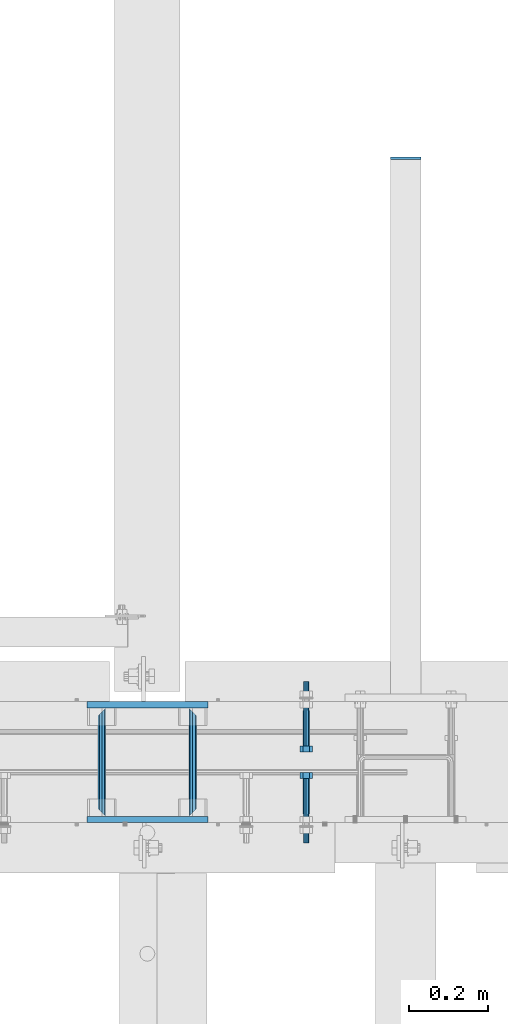
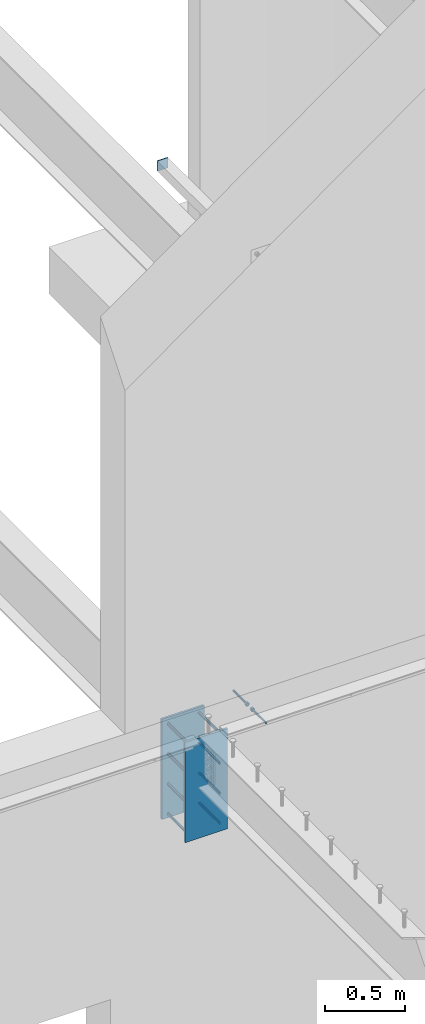
# One storey, part 435 of 975: 13 beams.
"""IFC2X3 building model written with IfcOpenShell, lengths in millimetres."""

from ifc_helpers import new_model, si_unit, frame, origin_with_axes, place, context, subcontext, project, spatial, faceted_brep, material, type_object, element, save


model = new_model("IFC2X3")

# Units and contexts
model_context = context("Model", 3, precision=1e-05, world=origin_with_axes())
body_context = subcontext(model_context, "Body", "Model", "MODEL_VIEW")
ifc_project = project(units=[si_unit("LENGTHUNIT", "METRE", prefix="MILLI"), si_unit("AREAUNIT", "SQUARE_METRE"), si_unit("VOLUMEUNIT", "CUBIC_METRE"), si_unit("MASSUNIT", "GRAM", prefix="KILO"), si_unit("TIMEUNIT", "SECOND"), si_unit("PLANEANGLEUNIT", "RADIAN"), si_unit("SOLIDANGLEUNIT", "STERADIAN"), si_unit("THERMODYNAMICTEMPERATUREUNIT", "DEGREE_CELSIUS"), si_unit("LUMINOUSINTENSITYUNIT", "LUMEN")], contexts=[model_context])

# Site, building, storey
site_placement = place(None, origin_with_axes())
site = spatial("IfcSite", under=ifc_project, at=site_placement, CompositionType="ELEMENT")
building_placement = place(site_placement, origin_with_axes())
building = spatial("IfcBuilding", under=site, at=building_placement, Name="Undefined", CompositionType="ELEMENT")
storey_placement = place(building_placement, origin_with_axes())
storey = spatial("IfcBuildingStorey", under=building, at=storey_placement, Name="Undefined", CompositionType="ELEMENT", Elevation=0.0)

# Beams
ifc_material_1 = material(Name="STEEL/F1554-36")
beam_type_1 = type_object("IfcBeamType", PredefinedType="NOTDEFINED")
beam_1_placement = place(storey_placement, frame((11258.5499755824, 20726.3999996637, 3886.2), z_axis=(0.0, 0.0, -1.0), x_axis=(0.0, -1.0, 0.0)))
element("IfcBeam", 1, at=beam_1_placement, inside=storey, type_object=beam_type_1, material=ifc_material_1, Name="HEADED_ANCHOR_BOLT", context=body_context, shape_type="Brep", body=[
    faceted_brep([(88.9000000184824, 7.94000001861696, -13.7499999799138), (88.8999999527368, 15.8800000758411, 2.00943759409711e-08), (104.774999952569, 15.8800001213949, 6.97191353538074e-08), (104.775000018315, 7.94000006417082, -13.7499999302891), (88.900000064019, -7.94000009583215, -13.7499999799147), (104.775000063852, -7.9400000502792, -13.74999993029), (88.9000000438027, -15.880000153059, 2.00925569515675e-08), (104.775000043643, -15.8800001075042, 6.9716406869702e-08), (88.8999999780608, -7.94000009583488, 13.7500000200998), (104.774999977893, -7.94000005028101, 13.7500000697237), (88.8999999325279, 7.94000001861514, 13.7500000201007), (104.774999932361, 7.940000064169, 13.7500000697246), (88.9000000119959, 3.78780480527439, -7.86545778426807), (88.8999999957159, 6.82538844544797, -5.4430656647246), (88.8999999799416, 8.51112018845743, -1.94260763148395), (88.8999999677944, 8.51112018845652, 1.94260767167179), (88.8999999616899, 6.82538844544615, 5.44306570491244), (88.8999999628249, 3.78780480527257, 7.86545782445592), (88.8999999709849, -3.86089595849626e-08, 8.72999956233434), (88.8999999845473, -3.7878048824914, 7.8654578244541), (88.9000000008309, -6.82538852266407, 5.44306570491153), (88.9000000166052, -8.51112026567444, 1.94260767166998), (88.9000000287488, -8.51112026567353, -1.94260763148577), (88.9000000348606, -6.82538852266407, -5.44306566472642), (88.9000000337182, -3.78780488248958, -7.86545778426898), (88.9000000255583, -3.86080500902608e-08, -8.72999952214832), (104.775000025395, 6.94581103743985e-09, -8.72999947252447), (104.775000011829, 3.78780485082825, -7.86545773464422), (104.774999995549, 6.82538849100092, -5.44306561510075), (104.774999979774, 8.51112023401038, -1.9426075818601), (104.774999967627, 8.51112023401038, 1.94260772129564), (104.774999961523, 6.82538849100092, 5.44306575453629), (104.774999962658, 3.78780485082643, 7.86545787407977), (104.774999970818, 6.94399204803631e-09, 8.7299996119591), (104.77499998438, -3.78780483693754, 7.86545787407886), (104.775000000664, -6.82538847711112, 5.44306575453538), (104.775000016438, -8.51112022012057, 1.94260772129473), (104.775000028581, -8.51112022012057, -1.94260758186101), (104.775000034693, -6.82538847711021, -5.44306561510166), (104.775000033551, -3.78780483693663, -7.86545773464422), (-2.99107341561466e-07, -5.61266007567065, 5.61266007566792), (-4.22995071858168e-07, -7.93750000000728, 0.0), (104.774999998088, -7.93749999999, -4.45652403868735e-11), (104.774999998088, -5.61266007565791, 5.61266007562426), (-1.09139364212751e-11, 1.81898940354586e-12, 7.9375), (104.774999998095, 1.18234311230481e-11, 7.93749999995816), (2.99089151667431e-07, 5.61266007567428, 5.61266007566792), (104.774999998102, 5.61266007568065, 5.61266007562517), (4.22980519942939e-07, 7.93750000001091, 0.0), (104.77499999811, 7.93750000001364, -4.36557456851006e-11), (2.99089151667431e-07, 5.61266007567428, -5.61266007566792), (104.774999998102, 5.61266007568156, -5.61266007571339), (-1.09139364212751e-11, 1.81898940354586e-12, -7.9375), (104.774999998099, 1.2732925824821e-11, -7.93750000004547), (-73.0249999592124, 5.05157065939329, -5.0515715445581), (-73.0249999269472, -1.85405951924622e-07, -7.14400069976364), (-73.0249999328516, -5.0515710302052, -5.05157154455992), (-73.0249999734697, -7.14400018541073, -6.9975976657588e-07), (-73.0250000250016, -5.05157103020611, 5.05157014504039), (-73.0250000572705, -1.85406861419324e-07, 7.1439993002441), (-73.0250000513661, 5.05157065939238, 5.05157014503948), (-73.025000010748, 7.14399981459792, -6.99758857081179e-07), (0.00625003290042514, 5.05157085007795, -5.05157087849238), (0.00625006516929716, 5.27870724909008e-09, -7.1440000336961), (0.00625005926485755, -5.05157083952145, -5.05157087849329), (0.00625001864682417, -7.14399999472516, -3.36940502165817e-08), (0.00624996711121639, -5.05157083952145, 5.05157081110519), (0.00624993484598235, 5.2777977543883e-09, 7.14399996631164), (0.00624994074678398, 5.05157085007704, 5.05157081110701), (0.00624998136845534, 7.14400000528167, -3.36922312271781e-08), (-2.99107341561466e-07, -5.61266007567065, -5.61266007566792), (104.774999998092, -5.612660075657, -5.6126600757143)], [[[0, 1, 2, 3]], [[4, 0, 3, 5]], [[6, 4, 5, 7]], [[8, 6, 7, 9]], [[10, 8, 9, 11]], [[0, 4, 6, 8, 10, 1], [12, 13, 14, 15, 16, 17, 18, 19, 20, 21, 22, 23, 24, 25]], [[12, 25, 26, 27]], [[13, 12, 27, 28]], [[14, 13, 28, 29]], [[15, 14, 29, 30]], [[16, 15, 30, 31]], [[17, 16, 31, 32]], [[18, 17, 32, 33]], [[19, 18, 33, 34]], [[20, 19, 34, 35]], [[21, 20, 35, 36]], [[22, 21, 36, 37]], [[23, 22, 37, 38]], [[24, 23, 38, 39]], [[25, 24, 39, 26]], [[9, 7, 5, 3, 2, 11], [38, 37, 36, 35, 34, 33, 32, 31, 30, 29, 28, 27, 26, 39]], [[1, 10, 11, 2]], [[40, 41, 42, 43]], [[44, 40, 43, 45]], [[46, 44, 45, 47]], [[48, 46, 47, 49]], [[50, 48, 49, 51]], [[52, 50, 51, 53]], [[54, 55, 56, 57, 58, 59, 60, 61]], [[55, 54, 62, 63]], [[56, 55, 63, 64]], [[57, 56, 64, 65]], [[58, 57, 65, 66]], [[59, 58, 66, 67]], [[60, 59, 67, 68]], [[61, 60, 68, 69]], [[54, 61, 69, 62]], [[40, 44, 46, 48, 50, 52, 70, 41], [68, 67, 66, 65, 64, 63, 62, 69]], [[41, 70, 71, 42]], [[53, 51, 49, 47, 45, 43, 42, 71]], [[70, 52, 53, 71]]]),
])
beam_2_placement = place(storey_placement, frame((11258.5499755824, 20466.05, 3886.2), z_axis=(0.0, 0.0, 1.0), x_axis=(0.0, 1.0, 0.0)))
element("IfcBeam", 2, at=beam_2_placement, inside=storey, type_object=beam_type_1, material=ifc_material_1, Name="HEADED_ANCHOR_BOLT", context=body_context, shape_type="Brep", body=[
    faceted_brep([(88.9000000184824, 7.94000001861696, -13.7499999799138), (88.8999999527368, 15.8800000758411, 2.00943759409711e-08), (104.774999952569, 15.8800001213949, 6.97191353538074e-08), (104.775000018315, 7.94000006417082, -13.7499999302891), (88.900000064019, -7.94000009583215, -13.7499999799147), (104.775000063852, -7.9400000502792, -13.74999993029), (88.9000000438027, -15.880000153059, 2.00925569515675e-08), (104.775000043643, -15.8800001075042, 6.9716406869702e-08), (88.8999999780608, -7.94000009583488, 13.7500000200998), (104.774999977893, -7.94000005028101, 13.7500000697237), (88.8999999325279, 7.94000001861514, 13.7500000201007), (104.774999932361, 7.940000064169, 13.7500000697246), (88.9000000119959, 3.78780480527439, -7.86545778426807), (88.8999999957159, 6.82538844544797, -5.4430656647246), (88.8999999799416, 8.51112018845743, -1.94260763148395), (88.8999999677944, 8.51112018845652, 1.94260767167179), (88.8999999616899, 6.82538844544615, 5.44306570491244), (88.8999999628249, 3.78780480527257, 7.86545782445592), (88.8999999709849, -3.86089595849626e-08, 8.72999956233434), (88.8999999845473, -3.7878048824914, 7.8654578244541), (88.9000000008309, -6.82538852266407, 5.44306570491153), (88.9000000166052, -8.51112026567444, 1.94260767166998), (88.9000000287488, -8.51112026567353, -1.94260763148577), (88.9000000348606, -6.82538852266407, -5.44306566472642), (88.9000000337182, -3.78780488248958, -7.86545778426898), (88.9000000255583, -3.86080500902608e-08, -8.72999952214832), (104.775000025395, 6.94581103743985e-09, -8.72999947252447), (104.775000011829, 3.78780485082825, -7.86545773464422), (104.774999995549, 6.82538849100092, -5.44306561510075), (104.774999979774, 8.51112023401038, -1.9426075818601), (104.774999967627, 8.51112023401038, 1.94260772129564), (104.774999961523, 6.82538849100092, 5.44306575453629), (104.774999962658, 3.78780485082643, 7.86545787407977), (104.774999970818, 6.94399204803631e-09, 8.7299996119591), (104.77499998438, -3.78780483693754, 7.86545787407886), (104.775000000664, -6.82538847711112, 5.44306575453538), (104.775000016438, -8.51112022012057, 1.94260772129473), (104.775000028581, -8.51112022012057, -1.94260758186101), (104.775000034693, -6.82538847711021, -5.44306561510166), (104.775000033551, -3.78780483693663, -7.86545773464422), (-2.99107341561466e-07, -5.61266007567065, 5.61266007566792), (-4.22995071858168e-07, -7.93750000000728, 0.0), (104.774999998088, -7.93749999999, -4.45652403868735e-11), (104.774999998088, -5.61266007565791, 5.61266007562426), (-1.09139364212751e-11, 1.81898940354586e-12, 7.9375), (104.774999998095, 1.18234311230481e-11, 7.93749999995816), (2.99089151667431e-07, 5.61266007567428, 5.61266007566792), (104.774999998102, 5.61266007568065, 5.61266007562517), (4.22980519942939e-07, 7.93750000001091, 0.0), (104.77499999811, 7.93750000001364, -4.36557456851006e-11), (2.99089151667431e-07, 5.61266007567428, -5.61266007566792), (104.774999998102, 5.61266007568156, -5.61266007571339), (-1.09139364212751e-11, 1.81898940354586e-12, -7.9375), (104.774999998099, 1.2732925824821e-11, -7.93750000004547), (-73.0249999592124, 5.05157065939329, -5.0515715445581), (-73.0249999269472, -1.85405951924622e-07, -7.14400069976364), (-73.0249999328516, -5.0515710302052, -5.05157154455992), (-73.0249999734697, -7.14400018541073, -6.9975976657588e-07), (-73.0250000250016, -5.05157103020611, 5.05157014504039), (-73.0250000572705, -1.85406861419324e-07, 7.1439993002441), (-73.0250000513661, 5.05157065939238, 5.05157014503948), (-73.025000010748, 7.14399981459792, -6.99758857081179e-07), (0.00625003290042514, 5.05157085007795, -5.05157087849238), (0.00625006516929716, 5.27870724909008e-09, -7.1440000336961), (0.00625005926485755, -5.05157083952145, -5.05157087849329), (0.00625001864682417, -7.14399999472516, -3.36940502165817e-08), (0.00624996711121639, -5.05157083952145, 5.05157081110519), (0.00624993484598235, 5.2777977543883e-09, 7.14399996631164), (0.00624994074678398, 5.05157085007704, 5.05157081110701), (0.00624998136845534, 7.14400000528167, -3.36922312271781e-08), (-2.99107341561466e-07, -5.61266007567065, -5.61266007566792), (104.774999998092, -5.612660075657, -5.6126600757143)], [[[0, 1, 2, 3]], [[4, 0, 3, 5]], [[6, 4, 5, 7]], [[8, 6, 7, 9]], [[10, 8, 9, 11]], [[0, 4, 6, 8, 10, 1], [12, 13, 14, 15, 16, 17, 18, 19, 20, 21, 22, 23, 24, 25]], [[12, 25, 26, 27]], [[13, 12, 27, 28]], [[14, 13, 28, 29]], [[15, 14, 29, 30]], [[16, 15, 30, 31]], [[17, 16, 31, 32]], [[18, 17, 32, 33]], [[19, 18, 33, 34]], [[20, 19, 34, 35]], [[21, 20, 35, 36]], [[22, 21, 36, 37]], [[23, 22, 37, 38]], [[24, 23, 38, 39]], [[25, 24, 39, 26]], [[9, 7, 5, 3, 2, 11], [38, 37, 36, 35, 34, 33, 32, 31, 30, 29, 28, 27, 26, 39]], [[1, 10, 11, 2]], [[40, 41, 42, 43]], [[44, 40, 43, 45]], [[46, 44, 45, 47]], [[48, 46, 47, 49]], [[50, 48, 49, 51]], [[52, 50, 51, 53]], [[54, 55, 56, 57, 58, 59, 60, 61]], [[55, 54, 62, 63]], [[56, 55, 63, 64]], [[57, 56, 64, 65]], [[58, 57, 65, 66]], [[59, 58, 66, 67]], [[60, 59, 67, 68]], [[61, 60, 68, 69]], [[54, 61, 69, 62]], [[40, 44, 46, 48, 50, 52, 70, 41], [68, 67, 66, 65, 64, 63, 62, 69]], [[41, 70, 71, 42]], [[53, 51, 49, 47, 45, 43, 42, 71]], [[70, 52, 53, 71]]]),
])
ifc_material_2 = material(Name="STEEL/A36")
beam_type_2 = type_object("IfcBeamType", PredefinedType="NOTDEFINED")
beam_3_placement = place(storey_placement, frame((11509.375, 22116.9399014879, 7035.8), z_axis=(1.0, 0.0, 0.0), x_axis=(0.0, 0.0, -1.0)))
element("IfcBeam", 3, at=beam_3_placement, inside=storey, type_object=beam_type_2, material=ifc_material_2, Name="PLATE", context=body_context, shape_type="Brep", body=[
    faceted_brep([(0.0, 3.17500000000018, -38.1000000000004), (0.0, 3.17500000000018, 38.1000000000004), (76.2000000000007, 3.17500000000018, 38.1000000000004), (76.2000000000007, 3.17500000000018, -38.1000000000004), (0.0, -3.17500000000018, 38.1000000000004), (76.2000000000007, -3.17500000000018, 38.1000000000004), (0.0, -3.17500000000018, -38.1000000000004), (76.2000000000007, -3.17500000000018, -38.1000000000004)], [[[0, 1, 2, 3]], [[1, 4, 5, 2]], [[4, 6, 7, 5]], [[6, 0, 3, 7]], [[5, 7, 3, 2]], [[6, 4, 1, 0]]]),
])
beam_type_3 = type_object("IfcBeamType", PredefinedType="NOTDEFINED")
beam_4_placement = place(storey_placement, frame((10972.8, 20459.7, 3403.6), z_axis=(0.0, 0.0, 1.0), x_axis=(0.0, 1.0, 0.0)))
element("IfcBeam", 4, at=beam_4_placement, inside=storey, type_object=beam_type_3, material=ifc_material_2, Name="ROD", context=body_context, shape_type="Brep", body=[
    faceted_brep([(19.0499992370605, -9.52499923706273, 0.0), (16.2601920907982, -6.73519209080223, 6.73519209080177), (9.52499999999782, 0.0, 9.52500000000009), (2.78980790919741, 6.73519209080223, 6.73519209080177), (0.0, 9.52499999999964, 0.0), (2.78980790919741, 6.73519209080223, -6.73519209080177), (9.52499999999782, 0.0, -9.52500000000009), (16.2601920907982, -6.73519209080223, -6.73519209080177), (273.050000000003, 9.52499999999782, 0.0), (270.260192090806, 6.73519209080223, 6.73519209080177), (263.525000000005, 0.0, 9.52500000000009), (256.789807909205, -6.73519209080223, 6.73519209080177), (254.000000762942, -9.52499999999964, 0.0), (256.789807909205, -6.73519209080223, -6.73519209080177), (263.525000000005, 0.0, -9.52500000000009), (270.260192090806, 6.73519209080223, -6.73519209080177)], [[[0, 1, 2, 3, 4, 5, 6, 7]], [[8, 9, 10, 11, 12, 13, 14, 15]], [[13, 12, 0, 7]], [[14, 13, 7, 6]], [[15, 14, 6, 5]], [[8, 15, 5, 4]], [[9, 8, 4, 3]], [[10, 9, 3, 2]], [[11, 10, 2, 1]], [[12, 11, 1, 0]]]),
])
beam_5_placement = place(storey_placement, frame((10744.2, 20459.7, 3403.6), z_axis=(0.0, 0.0, 1.0), x_axis=(0.0, 1.0, 0.0)))
element("IfcBeam", 5, at=beam_5_placement, inside=storey, type_object=beam_type_3, material=ifc_material_2, Name="ROD", context=body_context, shape_type="Brep", body=[
    faceted_brep([(19.0499992370605, 9.52499923706091, 0.0), (16.2601920908019, 6.73519209080223, -6.73519209080177), (9.52499999999782, 0.0, -9.52500000000009), (2.78980790919741, -6.73519209080223, -6.73519209080177), (0.0, -9.52499999999964, 0.0), (2.78980790919741, -6.73519209080223, 6.73519209080177), (9.52499999999782, 0.0, 9.52500000000009), (16.2601920908019, 6.73519209080223, 6.73519209080177), (273.050000000003, -9.52499999999964, 0.0), (270.260192090806, -6.73519209080223, -6.73519209080177), (263.525000000005, 0.0, -9.52500000000009), (256.789807909201, 6.73519209080223, -6.73519209080177), (254.000000762942, 9.52499999999964, 0.0), (256.789807909201, 6.73519209080223, 6.73519209080177), (263.525000000005, 0.0, 9.52500000000009), (270.260192090806, -6.73519209080223, 6.73519209080177)], [[[0, 1, 2, 3, 4, 5, 6, 7]], [[8, 9, 10, 11, 12, 13, 14, 15]], [[13, 12, 0, 7]], [[14, 13, 7, 6]], [[15, 14, 6, 5]], [[8, 15, 5, 4]], [[9, 8, 4, 3]], [[10, 9, 3, 2]], [[11, 10, 2, 1]], [[12, 11, 1, 0]]]),
])
beam_6_placement = place(storey_placement, frame((10972.8, 20459.7, 3632.2), z_axis=(0.0, 0.0, 1.0), x_axis=(0.0, 1.0, 0.0)))
element("IfcBeam", 6, at=beam_6_placement, inside=storey, type_object=beam_type_3, material=ifc_material_2, Name="ROD", context=body_context, shape_type="Brep", body=[
    faceted_brep([(19.0499992370605, -9.52499923706273, 0.0), (16.2601920907982, -6.73519209080223, 6.73519209080177), (9.52499999999782, 0.0, 9.52500000000009), (2.78980790919741, 6.73519209080223, 6.73519209080177), (0.0, 9.52499999999964, 0.0), (2.78980790919741, 6.73519209080223, -6.73519209080177), (9.52499999999782, 0.0, -9.52500000000009), (16.2601920907982, -6.73519209080223, -6.73519209080177), (273.050000000003, 9.52499999999782, 0.0), (270.260192090806, 6.73519209080223, 6.73519209080177), (263.525000000005, 0.0, 9.52500000000009), (256.789807909205, -6.73519209080223, 6.73519209080177), (254.000000762942, -9.52499999999964, 0.0), (256.789807909205, -6.73519209080223, -6.73519209080177), (263.525000000005, 0.0, -9.52500000000009), (270.260192090806, 6.73519209080223, -6.73519209080177)], [[[0, 1, 2, 3, 4, 5, 6, 7]], [[8, 9, 10, 11, 12, 13, 14, 15]], [[13, 12, 0, 7]], [[14, 13, 7, 6]], [[15, 14, 6, 5]], [[8, 15, 5, 4]], [[9, 8, 4, 3]], [[10, 9, 3, 2]], [[11, 10, 2, 1]], [[12, 11, 1, 0]]]),
])
beam_7_placement = place(storey_placement, frame((10744.2, 20459.7, 3632.2), z_axis=(0.0, 0.0, 1.0), x_axis=(0.0, 1.0, 0.0)))
element("IfcBeam", 7, at=beam_7_placement, inside=storey, type_object=beam_type_3, material=ifc_material_2, Name="ROD", context=body_context, shape_type="Brep", body=[
    faceted_brep([(19.0499992370605, 9.52499923706091, 0.0), (16.2601920908019, 6.73519209080223, -6.73519209080177), (9.52499999999782, 0.0, -9.52500000000009), (2.78980790919741, -6.73519209080223, -6.73519209080177), (0.0, -9.52499999999964, 0.0), (2.78980790919741, -6.73519209080223, 6.73519209080177), (9.52499999999782, 0.0, 9.52500000000009), (16.2601920908019, 6.73519209080223, 6.73519209080177), (273.050000000003, -9.52499999999964, 0.0), (270.260192090806, -6.73519209080223, -6.73519209080177), (263.525000000005, 0.0, -9.52500000000009), (256.789807909201, 6.73519209080223, -6.73519209080177), (254.000000762942, 9.52499999999964, 0.0), (256.789807909201, 6.73519209080223, 6.73519209080177), (263.525000000005, 0.0, 9.52500000000009), (270.260192090806, -6.73519209080223, 6.73519209080177)], [[[0, 1, 2, 3, 4, 5, 6, 7]], [[8, 9, 10, 11, 12, 13, 14, 15]], [[13, 12, 0, 7]], [[14, 13, 7, 6]], [[15, 14, 6, 5]], [[8, 15, 5, 4]], [[9, 8, 4, 3]], [[10, 9, 3, 2]], [[11, 10, 2, 1]], [[12, 11, 1, 0]]]),
])
beam_8_placement = place(storey_placement, frame((10972.8, 20459.7, 3175.0), z_axis=(0.0, 0.0, 1.0), x_axis=(0.0, 1.0, 0.0)))
element("IfcBeam", 8, at=beam_8_placement, inside=storey, type_object=beam_type_3, material=ifc_material_2, Name="ROD", context=body_context, shape_type="Brep", body=[
    faceted_brep([(19.0499992370605, -9.52499923706273, 0.0), (16.2601920907982, -6.73519209080223, 6.73519209080177), (9.52499999999782, 0.0, 9.52500000000009), (2.78980790919741, 6.73519209080223, 6.73519209080177), (0.0, 9.52499999999964, 0.0), (2.78980790919741, 6.73519209080223, -6.73519209080177), (9.52499999999782, 0.0, -9.52500000000009), (16.2601920907982, -6.73519209080223, -6.73519209080177), (273.050000000003, 9.52499999999782, 0.0), (270.260192090806, 6.73519209080223, 6.73519209080177), (263.525000000005, 0.0, 9.52500000000009), (256.789807909205, -6.73519209080223, 6.73519209080177), (254.000000762942, -9.52499999999964, 0.0), (256.789807909205, -6.73519209080223, -6.73519209080177), (263.525000000005, 0.0, -9.52500000000009), (270.260192090806, 6.73519209080223, -6.73519209080177)], [[[0, 1, 2, 3, 4, 5, 6, 7]], [[8, 9, 10, 11, 12, 13, 14, 15]], [[13, 12, 0, 7]], [[14, 13, 7, 6]], [[15, 14, 6, 5]], [[8, 15, 5, 4]], [[9, 8, 4, 3]], [[10, 9, 3, 2]], [[11, 10, 2, 1]], [[12, 11, 1, 0]]]),
])
beam_9_placement = place(storey_placement, frame((10744.2, 20459.7, 3175.0), z_axis=(0.0, 0.0, 1.0), x_axis=(0.0, 1.0, 0.0)))
element("IfcBeam", 9, at=beam_9_placement, inside=storey, type_object=beam_type_3, material=ifc_material_2, Name="ROD", context=body_context, shape_type="Brep", body=[
    faceted_brep([(19.0499992370605, 9.52499923706091, 0.0), (16.2601920908019, 6.73519209080223, -6.73519209080177), (9.52499999999782, 0.0, -9.52500000000009), (2.78980790919741, -6.73519209080223, -6.73519209080177), (0.0, -9.52499999999964, 0.0), (2.78980790919741, -6.73519209080223, 6.73519209080177), (9.52499999999782, 0.0, 9.52500000000009), (16.2601920908019, 6.73519209080223, 6.73519209080177), (273.050000000003, -9.52499999999964, 0.0), (270.260192090806, -6.73519209080223, -6.73519209080177), (263.525000000005, 0.0, -9.52500000000009), (256.789807909201, 6.73519209080223, -6.73519209080177), (254.000000762942, 9.52499999999964, 0.0), (256.789807909201, 6.73519209080223, 6.73519209080177), (263.525000000005, 0.0, 9.52500000000009), (270.260192090806, -6.73519209080223, 6.73519209080177)], [[[0, 1, 2, 3, 4, 5, 6, 7]], [[8, 9, 10, 11, 12, 13, 14, 15]], [[13, 12, 0, 7]], [[14, 13, 7, 6]], [[15, 14, 6, 5]], [[8, 15, 5, 4]], [[9, 8, 4, 3]], [[10, 9, 3, 2]], [[11, 10, 2, 1]], [[12, 11, 1, 0]]]),
])
beam_10_placement = place(storey_placement, frame((10972.8, 20459.7, 3860.8), z_axis=(0.0, 0.0, 1.0), x_axis=(0.0, 1.0, 0.0)))
element("IfcBeam", 10, at=beam_10_placement, inside=storey, type_object=beam_type_3, material=ifc_material_2, Name="ROD", context=body_context, shape_type="Brep", body=[
    faceted_brep([(19.0499992370605, -9.52499923706273, 0.0), (16.2601920907982, -6.73519209080223, 6.73519209080177), (9.52499999999782, 0.0, 9.52500000000009), (2.78980790919741, 6.73519209080223, 6.73519209080177), (0.0, 9.52499999999964, 0.0), (2.78980790919741, 6.73519209080223, -6.73519209080177), (9.52499999999782, 0.0, -9.52500000000009), (16.2601920907982, -6.73519209080223, -6.73519209080177), (273.050000000003, 9.52499999999782, 0.0), (270.260192090806, 6.73519209080223, 6.73519209080177), (263.525000000005, 0.0, 9.52500000000009), (256.789807909205, -6.73519209080223, 6.73519209080177), (254.000000762942, -9.52499999999964, 0.0), (256.789807909205, -6.73519209080223, -6.73519209080177), (263.525000000005, 0.0, -9.52500000000009), (270.260192090806, 6.73519209080223, -6.73519209080177)], [[[0, 1, 2, 3, 4, 5, 6, 7]], [[8, 9, 10, 11, 12, 13, 14, 15]], [[13, 12, 0, 7]], [[14, 13, 7, 6]], [[15, 14, 6, 5]], [[8, 15, 5, 4]], [[9, 8, 4, 3]], [[10, 9, 3, 2]], [[11, 10, 2, 1]], [[12, 11, 1, 0]]]),
])
beam_11_placement = place(storey_placement, frame((10744.2, 20459.7, 3860.8), z_axis=(0.0, 0.0, 1.0), x_axis=(0.0, 1.0, 0.0)))
element("IfcBeam", 11, at=beam_11_placement, inside=storey, type_object=beam_type_3, material=ifc_material_2, Name="ROD", context=body_context, shape_type="Brep", body=[
    faceted_brep([(19.0499992370605, 9.52499923706091, 0.0), (16.2601920908019, 6.73519209080223, -6.73519209080177), (9.52499999999782, 0.0, -9.52500000000009), (2.78980790919741, -6.73519209080223, -6.73519209080177), (0.0, -9.52499999999964, 0.0), (2.78980790919741, -6.73519209080223, 6.73519209080177), (9.52499999999782, 0.0, 9.52500000000009), (16.2601920908019, 6.73519209080223, 6.73519209080177), (273.050000000003, -9.52499999999964, 0.0), (270.260192090806, -6.73519209080223, -6.73519209080177), (263.525000000005, 0.0, -9.52500000000009), (256.789807909201, 6.73519209080223, -6.73519209080177), (254.000000762942, 9.52499999999964, 0.0), (256.789807909201, 6.73519209080223, 6.73519209080177), (263.525000000005, 0.0, 9.52500000000009), (270.260192090806, -6.73519209080223, 6.73519209080177)], [[[0, 1, 2, 3, 4, 5, 6, 7]], [[8, 9, 10, 11, 12, 13, 14, 15]], [[13, 12, 0, 7]], [[14, 13, 7, 6]], [[15, 14, 6, 5]], [[8, 15, 5, 4]], [[9, 8, 4, 3]], [[10, 9, 3, 2]], [[11, 10, 2, 1]], [[12, 11, 1, 0]]]),
])
beam_type_4 = type_object("IfcBeamType", PredefinedType="NOTDEFINED")
for number, where, z_axis, x_axis, name in (
    (12, (10706.1, 20451.7625, 3517.9), (0.0, 0.0, 1.0), (1.0, 0.0, 0.0), "EMBED_PLATE"),
    (13, (10706.1, 20740.6875, 3517.9), (0.0, 0.0, 1.0), (1.0, 0.0, 0.0), "EMBED_PLATE"),
):
    element("IfcBeam", number, at=place(storey_placement, frame(where, z_axis=z_axis, x_axis=x_axis)), inside=storey, type_object=beam_type_4, material=ifc_material_2, Name=name, context=body_context, shape_type="Brep", body=[
        faceted_brep([(0.0, 7.9375, -381.0), (0.0, 7.9375, 381.0), (304.800000000001, 7.9375, 381.0), (304.800000000001, 7.9375, -381.0), (0.0, -7.9375, 381.0), (304.800000000001, -7.9375, 381.0), (0.0, -7.9375, -381.0), (304.800000000001, -7.9375, -381.0)], [[[0, 1, 2, 3]], [[1, 4, 5, 2]], [[4, 6, 7, 5]], [[6, 0, 3, 7]], [[5, 7, 3, 2]], [[6, 4, 1, 0]]]),
    ])

save(model, "model.ifc")
